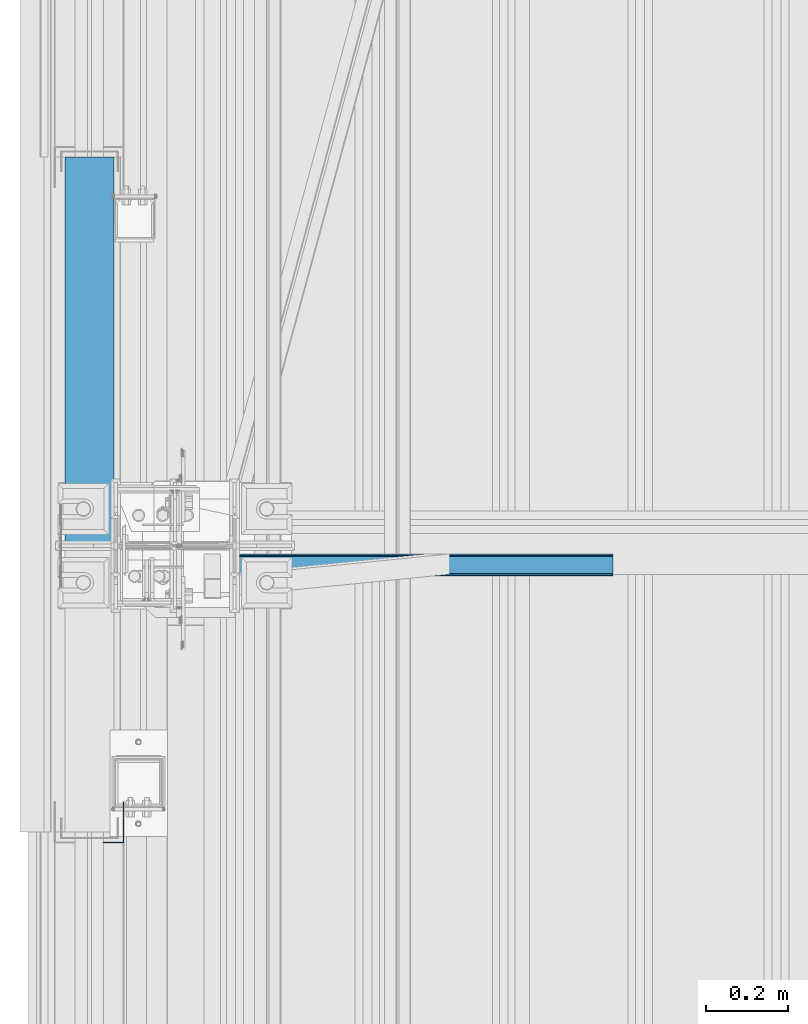
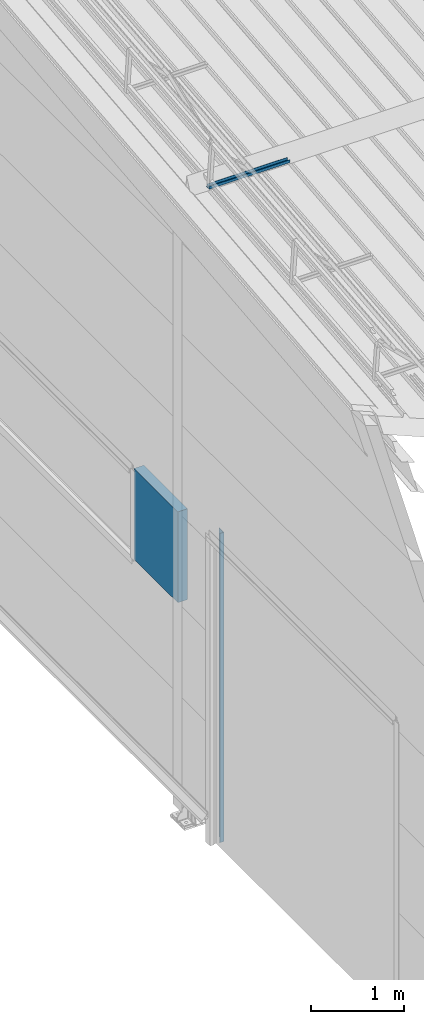
# One storey, part 32 of 709: 3 beams, 3 elements without a shape of their own.
"""IFC4 building model written with IfcOpenShell, lengths in millimetres."""

from ifc_helpers import new_model, si_unit, direction, frame, origin_with_axes, place, context, subcontext, project, spatial, line, indexed_curve, outline, extrude, material, element, aggregate, save


model = new_model("IFC4")

# Units and contexts
model_context = context("Model", 3, precision=0.2, world=origin_with_axes(), true_north=direction((0.0, 1.0)))
body_context = subcontext(model_context, "Body", "Model", "MODEL_VIEW")
ifc_project = project(units=[si_unit("LENGTHUNIT", "METRE", prefix="MILLI"), si_unit("AREAUNIT", "SQUARE_METRE"), si_unit("VOLUMEUNIT", "CUBIC_METRE"), si_unit("MASSUNIT", "GRAM", prefix="KILO"), si_unit("TIMEUNIT", "SECOND"), si_unit("PLANEANGLEUNIT", "RADIAN"), si_unit("SOLIDANGLEUNIT", "STERADIAN"), si_unit("THERMODYNAMICTEMPERATUREUNIT", "DEGREE_CELSIUS"), si_unit("LUMINOUSINTENSITYUNIT", "LUMEN")], contexts=[model_context])

# Site, building, storey
site_placement = place(None, origin_with_axes())
site = spatial("IfcSite", under=ifc_project, at=site_placement, CompositionType="ELEMENT")
building_placement = place(site_placement, origin_with_axes())
building = spatial("IfcBuilding", under=site, at=building_placement, Name="Undefined", CompositionType="ELEMENT")
storey_placement = place(building_placement, origin_with_axes())
storey = spatial("IfcBuildingStorey", under=building, at=storey_placement, Name="Undefined", CompositionType="ELEMENT", Elevation=0.0)

# Assembly, beam
assembly_1_placement = place(storey_placement, frame((220.0, 5453.23325, 8045.59294), z_axis=(0.0, -0.099503719, 0.9950371902), x_axis=(1.0, 0.0, 0.0)))
assembly_1 = element("IfcElementAssembly", 1, at=assembly_1_placement, inside=storey)
ifc_material_1 = material(Name="Steel_Undefined", Category="STEEL")
beam_1_placement = place(assembly_1_placement, origin_with_axes())
beam_1 = element("IfcBeam", 2, at=beam_1_placement, material=ifc_material_1, ObjectType="601", context=body_context, shape_type="SolidModel", body=[
    extrude(outline(indexed_curve([(-20.0, -25.0), (20.0, -25.0), (20.0, -22.5), (-17.5, -22.5), (-17.5, 22.5), (20.0, 22.5), (20.0, 25.0), (-20.0, 25.0)], segments=[line(1, 2, 3, 4, 5, 6, 7, 8, 1)])), frame((0.0, 0.0, 0.0), z_axis=(-1.0, 0.0, 0.0), x_axis=(0.0, 0.0, 1.0)), (0.0, 0.0, -1.0), 1000.0),
])
aggregate(assembly_1, [beam_1])

assembly_2_placement = place(storey_placement, frame((-60.0, 5510.0, 3275.0), z_axis=(0.0, 0.0, -1.0), x_axis=(0.0, 1.0, 0.0)))
assembly_2 = element("IfcElementAssembly", 3, at=assembly_2_placement, inside=storey)
ifc_material_2 = material(Name="Insulation", Category="Insulation")
beam_2_placement = place(assembly_2_placement, origin_with_axes())
beam_2 = element("IfcBeam", 4, at=beam_2_placement, material=ifc_material_2, ObjectType="P-138", context=body_context, shape_type="SolidModel", body=[
    extrude(outline(indexed_curve([(-595.0, -60.0), (595.0, -60.0), (595.0, 60.0), (-595.0, 60.0)], segments=[line(1, 2, 3, 4, 1)])), frame((0.0, 0.0, 0.0), z_axis=(-1.0, 0.0, 0.0), x_axis=(0.0, 0.0, 1.0)), (0.0, 0.0, -1.0), 940.0),
])
aggregate(assembly_2, [beam_2])

assembly_3_placement = place(storey_placement, frame((-1.0, 4775.0, 4000.0), z_axis=(1.0, 0.0, 0.0), x_axis=(0.0, 0.0, -1.0)))
assembly_3 = element("IfcElementAssembly", 5, at=assembly_3_placement, inside=storey)
beam_3_placement = place(assembly_3_placement, origin_with_axes())
beam_3 = element("IfcBeam", 6, at=beam_3_placement, material=ifc_material_1, context=body_context, shape_type="SolidModel", body=[
    extrude(outline(indexed_curve([(-25.0, -1.0), (25.0, -1.0), (25.0, 99.0), (23.0, 99.0), (23.0, 1.0), (-25.0, 1.0)], segments=[line(1, 2, 3, 4, 5, 6, 1)])), frame((0.0, 0.0, 0.0), z_axis=(-1.0, 0.0, 0.0), x_axis=(0.0, 0.0, 1.0)), (0.0, 0.0, -1.0), 4050.0),
])
aggregate(assembly_3, [beam_3])

save(model, "model.ifc")
